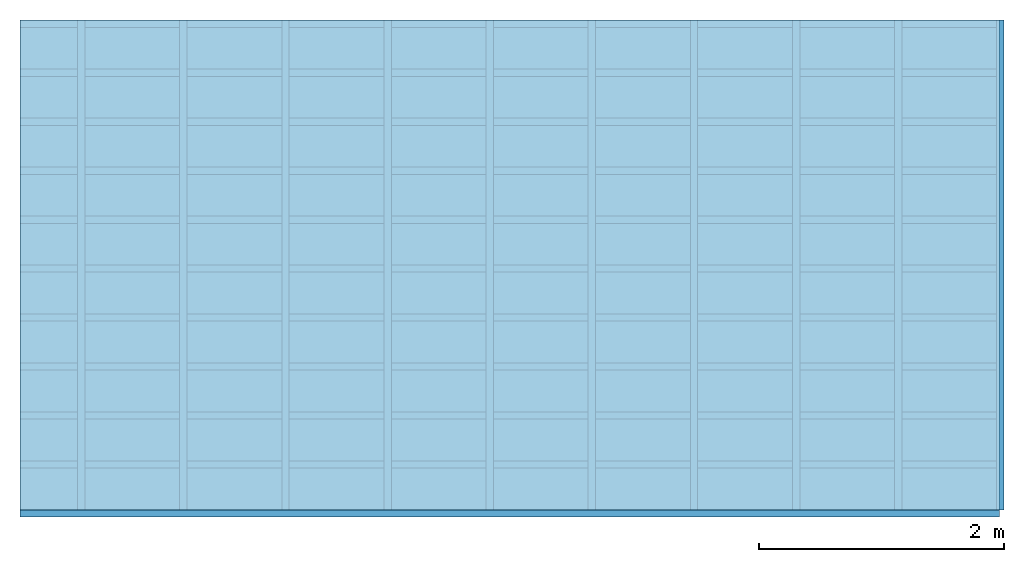
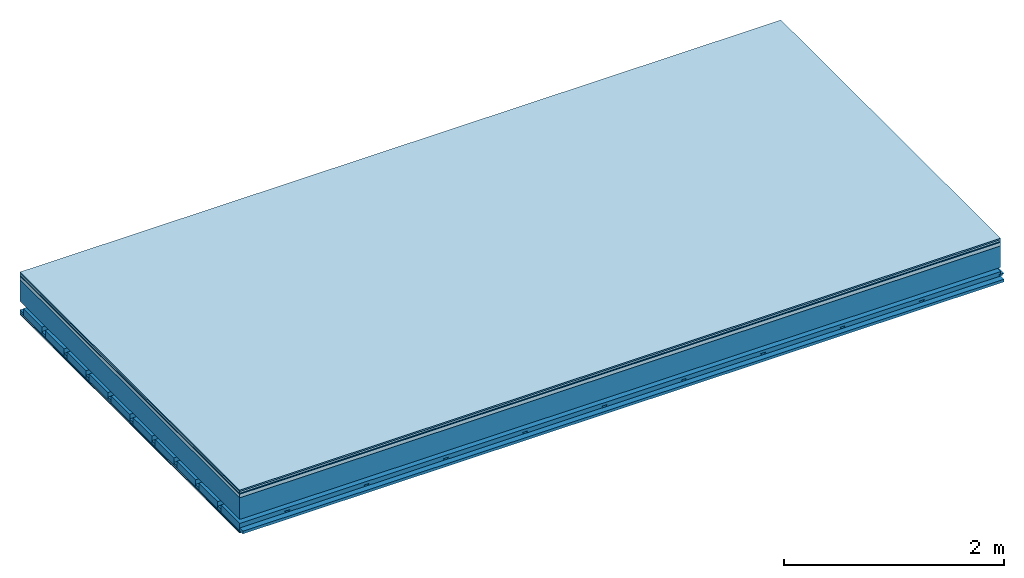
# One storey: 7 plates, 4 members, 1 element without a shape of its own.
"""IFC4 building model written with IfcOpenShell, lengths in metres."""

from ifc_helpers import new_model, si_unit, derived_unit, direction, frame, frame_2d, origin, origin_with_axes, place, context, project, spatial, polyline, rectangle, outline, extrude, material, layer, layer_set, type_object, element, aggregate, save


model = new_model("IFC4")

# Units and contexts
plan_context = context("Plan", 3, precision=1e-05, world=origin(), true_north=direction((0.0, 1.0)))
model_context = context("Model", 3, precision=1e-05, world=origin(), true_north=direction((0.0, 1.0)))
ifc_project = project(units=[si_unit("LENGTHUNIT", "METRE"), derived_unit("SOUNDPRESSUREUNIT", [(si_unit("PRESSUREUNIT", "PASCAL", prefix="MICRO"), 0)]), si_unit("ENERGYUNIT", "JOULE", prefix="MEGA"), si_unit("MASSUNIT", "GRAM", prefix="KILO"), derived_unit("THERMALTRANSMITTANCEUNIT", [(si_unit("POWERUNIT", "WATT"), 1), (si_unit("AREAUNIT", "SQUARE_METRE"), -1), (si_unit("THERMODYNAMICTEMPERATUREUNIT", "KELVIN"), -1)]), derived_unit("AREADENSITYUNIT", [(si_unit("MASSUNIT", "GRAM", prefix="KILO"), 1), (si_unit("AREAUNIT", "SQUARE_METRE"), -1)]), derived_unit("USERDEFINED", [(si_unit("ENERGYUNIT", "JOULE", prefix="MEGA"), 1), (si_unit("AREAUNIT", "SQUARE_METRE"), -1)])], contexts=[plan_context, model_context])

# Site, building, storey
site = spatial("IfcSite", under=ifc_project)
building_placement = place(None, origin())
building = spatial("IfcBuilding", under=site, at=building_placement)
storey_placement = place(building_placement, origin())
storey = spatial("IfcBuildingStorey", under=building, at=storey_placement)

# Slab, members, plates
ifc_material_1 = material(Category="11.013")
ifc_layer_1 = layer(ifc_material_1, 0.015, Name="Flooring")
ifc_material_2 = material(Category="03.007")
ifc_layer_2 = layer(ifc_material_2, 0.02, Name="On-material")
ifc_material_3 = material(Name="Wood fiber generic product", Category="10.009")
ifc_layer_3 = layer(ifc_material_3, 0.01, Name="Impact sound insulation")
ifc_material_4 = material(Name="Concrete panels", Category="02.007")
ifc_layer_4 = layer(ifc_material_4, 0.04, Name="on Supporting structure")
ifc_material_5 = material(Name="no composite action")
ifc_layer_5 = layer(ifc_material_5, 0.0, Name="Bond")
ifc_layer_6 = layer(None, 0.24, Name="Supporting structure")
ifc_layer_7 = layer(ifc_material_5, 0.0, Name="Bond")
ifc_layer_8 = layer(None, 0.095, Name="Coupling")
ifc_layer_9 = layer(None, 0.03, Name="Battens / profiles")
ifc_material_6 = material(Name="Plasterboard type A", Category="03.008")
ifc_layer_10 = layer(ifc_material_6, 0.0125, Name="Ceiling covering 1st layer")
ifc_layer_11 = layer(ifc_material_6, 0.0125, Name="Ceiling covering layer 2")
ifc_material_7 = material(Category="04.001")
ifc_layer_12 = layer(ifc_material_7, 0.003, Name="Surface / treatment")
ifc_layer_set = layer_set([ifc_layer_1, ifc_layer_2, ifc_layer_3, ifc_layer_4, ifc_layer_5, ifc_layer_6, ifc_layer_7, ifc_layer_8, ifc_layer_9, ifc_layer_10, ifc_layer_11, ifc_layer_12])
slab_type = type_object("IfcSlabType", Name="A2138", PredefinedType="NOTDEFINED", material=ifc_layer_set)
slab_placement = place(None, frame((0.0, 0.0, 0.0), z_axis=(0.0, 0.0, -1.0), x_axis=(1.0, 0.0, 0.0)))
slab = element("IfcSlab", 1, at=slab_placement, inside=storey, type_object=slab_type, material=ifc_layer_set, Name="Slab #1")
ifc_material_8 = material(Name="Solid timber panel")
member_1_placement = place(slab_placement, origin())
member_1 = element("IfcMember", 2, at=member_1_placement, material=ifc_material_8, Name="Supporting structure", context=plan_context, shape_type="SweptSolid", body=[
    extrude(rectangle(XDim=1.0, YDim=0.24, at=frame_2d((0.5, 0.12), x_axis=(1.0, 0.0))), frame((0.0, 4.0, 0.085), z_axis=(0.0, -1.0, 0.0), x_axis=(1.0, 0.0, 0.0)), (0.0, 0.0, 1.0), 4.0),
    extrude(rectangle(XDim=1.0, YDim=0.24, at=frame_2d((0.5, 0.12), x_axis=(1.0, 0.0))), frame((1.0, 4.0, 0.085), z_axis=(0.0, -1.0, 0.0), x_axis=(1.0, 0.0, 0.0)), (0.0, 0.0, 1.0), 4.0),
    extrude(rectangle(XDim=1.0, YDim=0.24, at=frame_2d((0.5, 0.12), x_axis=(1.0, 0.0))), frame((2.0, 4.0, 0.085), z_axis=(0.0, -1.0, 0.0), x_axis=(1.0, 0.0, 0.0)), (0.0, 0.0, 1.0), 4.0),
    extrude(rectangle(XDim=1.0, YDim=0.24, at=frame_2d((0.5, 0.12), x_axis=(1.0, 0.0))), frame((3.0, 4.0, 0.085), z_axis=(0.0, -1.0, 0.0), x_axis=(1.0, 0.0, 0.0)), (0.0, 0.0, 1.0), 4.0),
    extrude(rectangle(XDim=1.0, YDim=0.24, at=frame_2d((0.5, 0.12), x_axis=(1.0, 0.0))), frame((4.0, 4.0, 0.085), z_axis=(0.0, -1.0, 0.0), x_axis=(1.0, 0.0, 0.0)), (0.0, 0.0, 1.0), 4.0),
    extrude(rectangle(XDim=1.0, YDim=0.24, at=frame_2d((0.5, 0.12), x_axis=(1.0, 0.0))), frame((5.0, 4.0, 0.085), z_axis=(0.0, -1.0, 0.0), x_axis=(1.0, 0.0, 0.0)), (0.0, 0.0, 1.0), 4.0),
    extrude(rectangle(XDim=1.0, YDim=0.24, at=frame_2d((0.5, 0.12), x_axis=(1.0, 0.0))), frame((6.0, 4.0, 0.085), z_axis=(0.0, -1.0, 0.0), x_axis=(1.0, 0.0, 0.0)), (0.0, 0.0, 1.0), 4.0),
    extrude(rectangle(XDim=1.0, YDim=0.24, at=frame_2d((0.5, 0.12), x_axis=(1.0, 0.0))), frame((7.0, 4.0, 0.085), z_axis=(0.0, -1.0, 0.0), x_axis=(1.0, 0.0, 0.0)), (0.0, 0.0, 1.0), 4.0),
])
ifc_material_9 = material()
member_2_placement = place(slab_placement, origin())
member_2 = element("IfcMember", 3, at=member_2_placement, material=ifc_material_9, Name="Coupling", context=plan_context, shape_type="SweptSolid", body=[
    extrude(outline(polyline([(0.0, 0.0), (0.06, 0.0), (0.04, 0.02), (0.02, 0.02), (0.0, 0.0)])), frame((0.47, 4.0, 0.4), z_axis=(0.0, -1.0, 0.0), x_axis=(1.0, 0.0, 0.0)), (0.0, 0.0, 1.0), 4.0),
    extrude(outline(polyline([(0.0, 0.0), (0.06, 0.0), (0.04, 0.02), (0.02, 0.02), (0.0, 0.0)])), frame((1.304, 4.0, 0.4), z_axis=(0.0, -1.0, 0.0), x_axis=(1.0, 0.0, 0.0)), (0.0, 0.0, 1.0), 4.0),
    extrude(outline(polyline([(0.0, 0.0), (0.06, 0.0), (0.04, 0.02), (0.02, 0.02), (0.0, 0.0)])), frame((2.138, 4.0, 0.4), z_axis=(0.0, -1.0, 0.0), x_axis=(1.0, 0.0, 0.0)), (0.0, 0.0, 1.0), 4.0),
    extrude(outline(polyline([(0.0, 0.0), (0.06, 0.0), (0.04, 0.02), (0.02, 0.02), (0.0, 0.0)])), frame((2.972, 4.0, 0.4), z_axis=(0.0, -1.0, 0.0), x_axis=(1.0, 0.0, 0.0)), (0.0, 0.0, 1.0), 4.0),
    extrude(outline(polyline([(0.0, 0.0), (0.06, 0.0), (0.04, 0.02), (0.02, 0.02), (0.0, 0.0)])), frame((3.806, 4.0, 0.4), z_axis=(0.0, -1.0, 0.0), x_axis=(1.0, 0.0, 0.0)), (0.0, 0.0, 1.0), 4.0),
    extrude(outline(polyline([(0.0, 0.0), (0.06, 0.0), (0.04, 0.02), (0.02, 0.02), (0.0, 0.0)])), frame((4.64, 4.0, 0.4), z_axis=(0.0, -1.0, 0.0), x_axis=(1.0, 0.0, 0.0)), (0.0, 0.0, 1.0), 4.0),
    extrude(outline(polyline([(0.0, 0.0), (0.06, 0.0), (0.04, 0.02), (0.02, 0.02), (0.0, 0.0)])), frame((5.474, 4.0, 0.4), z_axis=(0.0, -1.0, 0.0), x_axis=(1.0, 0.0, 0.0)), (0.0, 0.0, 1.0), 4.0),
    extrude(outline(polyline([(0.0, 0.0), (0.06, 0.0), (0.04, 0.02), (0.02, 0.02), (0.0, 0.0)])), frame((6.308, 4.0, 0.4), z_axis=(0.0, -1.0, 0.0), x_axis=(1.0, 0.0, 0.0)), (0.0, 0.0, 1.0), 4.0),
    extrude(outline(polyline([(0.0, 0.0), (0.06, 0.0), (0.04, 0.02), (0.02, 0.02), (0.0, 0.0)])), frame((7.142, 4.0, 0.4), z_axis=(0.0, -1.0, 0.0), x_axis=(1.0, 0.0, 0.0)), (0.0, 0.0, 1.0), 4.0),
    extrude(outline(polyline([(0.0, 0.0), (0.06, 0.0), (0.04, 0.02), (0.02, 0.02), (0.0, 0.0)])), frame((7.976, 4.0, 0.4), z_axis=(0.0, -1.0, 0.0), x_axis=(1.0, 0.0, 0.0)), (0.0, 0.0, 1.0), 4.0),
])
member_3_placement = place(slab_placement, origin())
member_3 = element("IfcMember", 4, at=member_3_placement, material=ifc_material_9, Name="Battens / profiles", context=plan_context, shape_type="SweptSolid", body=[
    extrude(rectangle(XDim=0.06, YDim=0.03, at=frame_2d((0.03, 0.015), x_axis=(1.0, 0.0))), frame((0.0, 0.0, 0.42), z_axis=(1.0, 0.0, 0.0), x_axis=(0.0, 1.0, 0.0)), (0.0, 0.0, 1.0), 8.0),
    extrude(rectangle(XDim=0.06, YDim=0.03, at=frame_2d((0.03, 0.015), x_axis=(1.0, 0.0))), frame((0.0, 0.4, 0.42), z_axis=(1.0, 0.0, 0.0), x_axis=(0.0, 1.0, 0.0)), (0.0, 0.0, 1.0), 8.0),
    extrude(rectangle(XDim=0.06, YDim=0.03, at=frame_2d((0.03, 0.015), x_axis=(1.0, 0.0))), frame((0.0, 0.8, 0.42), z_axis=(1.0, 0.0, 0.0), x_axis=(0.0, 1.0, 0.0)), (0.0, 0.0, 1.0), 8.0),
    extrude(rectangle(XDim=0.06, YDim=0.03, at=frame_2d((0.03, 0.015), x_axis=(1.0, 0.0))), frame((0.0, 1.2, 0.42), z_axis=(1.0, 0.0, 0.0), x_axis=(0.0, 1.0, 0.0)), (0.0, 0.0, 1.0), 8.0),
    extrude(rectangle(XDim=0.06, YDim=0.03, at=frame_2d((0.03, 0.015), x_axis=(1.0, 0.0))), frame((0.0, 1.6, 0.42), z_axis=(1.0, 0.0, 0.0), x_axis=(0.0, 1.0, 0.0)), (0.0, 0.0, 1.0), 8.0),
    extrude(rectangle(XDim=0.06, YDim=0.03, at=frame_2d((0.03, 0.015), x_axis=(1.0, 0.0))), frame((0.0, 2.0, 0.42), z_axis=(1.0, 0.0, 0.0), x_axis=(0.0, 1.0, 0.0)), (0.0, 0.0, 1.0), 8.0),
    extrude(rectangle(XDim=0.06, YDim=0.03, at=frame_2d((0.03, 0.015), x_axis=(1.0, 0.0))), frame((0.0, 2.4, 0.42), z_axis=(1.0, 0.0, 0.0), x_axis=(0.0, 1.0, 0.0)), (0.0, 0.0, 1.0), 8.0),
    extrude(rectangle(XDim=0.06, YDim=0.03, at=frame_2d((0.03, 0.015), x_axis=(1.0, 0.0))), frame((0.0, 2.8, 0.42), z_axis=(1.0, 0.0, 0.0), x_axis=(0.0, 1.0, 0.0)), (0.0, 0.0, 1.0), 8.0),
    extrude(rectangle(XDim=0.06, YDim=0.03, at=frame_2d((0.03, 0.015), x_axis=(1.0, 0.0))), frame((0.0, 3.2, 0.42), z_axis=(1.0, 0.0, 0.0), x_axis=(0.0, 1.0, 0.0)), (0.0, 0.0, 1.0), 8.0),
    extrude(rectangle(XDim=0.06, YDim=0.03, at=frame_2d((0.03, 0.015), x_axis=(1.0, 0.0))), frame((0.0, 3.6, 0.42), z_axis=(1.0, 0.0, 0.0), x_axis=(0.0, 1.0, 0.0)), (0.0, 0.0, 1.0), 8.0),
    extrude(rectangle(XDim=0.06, YDim=0.03, at=frame_2d((0.03, 0.015), x_axis=(1.0, 0.0))), frame((0.0, 4.0, 0.42), z_axis=(1.0, 0.0, 0.0), x_axis=(0.0, 1.0, 0.0)), (0.0, 0.0, 1.0), 8.0),
])
ifc_material_10 = material()
member_4_placement = place(slab_placement, origin())
member_4 = element("IfcMember", 5, at=member_4_placement, material=ifc_material_10, Name="Cavity", context=plan_context, shape_type="SweptSolid", body=[
    extrude(rectangle(XDim=0.34, YDim=0.08, at=frame_2d((0.17, 0.04), x_axis=(1.0, 0.0))), frame((0.0, 0.06, 0.37), z_axis=(1.0, 0.0, 0.0), x_axis=(0.0, 1.0, 0.0)), (0.0, 0.0, 1.0), 8.0),
    extrude(rectangle(XDim=0.34, YDim=0.08, at=frame_2d((0.17, 0.04), x_axis=(1.0, 0.0))), frame((0.0, 0.46, 0.37), z_axis=(1.0, 0.0, 0.0), x_axis=(0.0, 1.0, 0.0)), (0.0, 0.0, 1.0), 8.0),
    extrude(rectangle(XDim=0.34, YDim=0.08, at=frame_2d((0.17, 0.04), x_axis=(1.0, 0.0))), frame((0.0, 0.86, 0.37), z_axis=(1.0, 0.0, 0.0), x_axis=(0.0, 1.0, 0.0)), (0.0, 0.0, 1.0), 8.0),
    extrude(rectangle(XDim=0.34, YDim=0.08, at=frame_2d((0.17, 0.04), x_axis=(1.0, 0.0))), frame((0.0, 1.26, 0.37), z_axis=(1.0, 0.0, 0.0), x_axis=(0.0, 1.0, 0.0)), (0.0, 0.0, 1.0), 8.0),
    extrude(rectangle(XDim=0.34, YDim=0.08, at=frame_2d((0.17, 0.04), x_axis=(1.0, 0.0))), frame((0.0, 1.66, 0.37), z_axis=(1.0, 0.0, 0.0), x_axis=(0.0, 1.0, 0.0)), (0.0, 0.0, 1.0), 8.0),
    extrude(rectangle(XDim=0.34, YDim=0.08, at=frame_2d((0.17, 0.04), x_axis=(1.0, 0.0))), frame((0.0, 2.06, 0.37), z_axis=(1.0, 0.0, 0.0), x_axis=(0.0, 1.0, 0.0)), (0.0, 0.0, 1.0), 8.0),
    extrude(rectangle(XDim=0.34, YDim=0.08, at=frame_2d((0.17, 0.04), x_axis=(1.0, 0.0))), frame((0.0, 2.46, 0.37), z_axis=(1.0, 0.0, 0.0), x_axis=(0.0, 1.0, 0.0)), (0.0, 0.0, 1.0), 8.0),
    extrude(rectangle(XDim=0.34, YDim=0.08, at=frame_2d((0.17, 0.04), x_axis=(1.0, 0.0))), frame((0.0, 2.86, 0.37), z_axis=(1.0, 0.0, 0.0), x_axis=(0.0, 1.0, 0.0)), (0.0, 0.0, 1.0), 8.0),
    extrude(rectangle(XDim=0.34, YDim=0.08, at=frame_2d((0.17, 0.04), x_axis=(1.0, 0.0))), frame((0.0, 3.26, 0.37), z_axis=(1.0, 0.0, 0.0), x_axis=(0.0, 1.0, 0.0)), (0.0, 0.0, 1.0), 8.0),
    extrude(rectangle(XDim=0.34, YDim=0.08, at=frame_2d((0.17, 0.04), x_axis=(1.0, 0.0))), frame((0.0, 3.66, 0.37), z_axis=(1.0, 0.0, 0.0), x_axis=(0.0, 1.0, 0.0)), (0.0, 0.0, 1.0), 8.0),
])
plate_1_placement = place(slab_placement, origin())
plate_1 = element("IfcPlate", 6, at=plate_1_placement, material=ifc_material_1, Name="Flooring", context=plan_context, shape_type="SweptSolid", body=[
    extrude(rectangle(XDim=8.0, YDim=4.0, at=frame_2d((4.0, 2.0), x_axis=(1.0, 0.0))), origin_with_axes(), (0.0, 0.0, 1.0), 0.015),
])
plate_2_placement = place(slab_placement, origin())
plate_2 = element("IfcPlate", 7, at=plate_2_placement, material=ifc_material_2, Name="On-material", context=plan_context, shape_type="SweptSolid", body=[
    extrude(rectangle(XDim=8.0, YDim=4.0, at=frame_2d((4.0, 2.0), x_axis=(1.0, 0.0))), frame((0.0, 0.0, 0.015), z_axis=(0.0, 0.0, 1.0), x_axis=(1.0, 0.0, 0.0)), (0.0, 0.0, 1.0), 0.02),
])
plate_3_placement = place(slab_placement, origin())
plate_3 = element("IfcPlate", 8, at=plate_3_placement, material=ifc_material_3, Name="Impact sound insulation", context=plan_context, shape_type="SweptSolid", body=[
    extrude(rectangle(XDim=8.0, YDim=4.0, at=frame_2d((4.0, 2.0), x_axis=(1.0, 0.0))), frame((0.0, 0.0, 0.035), z_axis=(0.0, 0.0, 1.0), x_axis=(1.0, 0.0, 0.0)), (0.0, 0.0, 1.0), 0.01),
])
plate_4_placement = place(slab_placement, origin())
plate_4 = element("IfcPlate", 9, at=plate_4_placement, material=ifc_material_4, Name="on Supporting structure", context=plan_context, shape_type="SweptSolid", body=[
    extrude(rectangle(XDim=8.0, YDim=4.0, at=frame_2d((4.0, 2.0), x_axis=(1.0, 0.0))), frame((0.0, 0.0, 0.045), z_axis=(0.0, 0.0, 1.0), x_axis=(1.0, 0.0, 0.0)), (0.0, 0.0, 1.0), 0.04),
])
plate_5_placement = place(slab_placement, origin())
plate_5 = element("IfcPlate", 10, at=plate_5_placement, material=ifc_material_6, Name="Ceiling covering 1st layer", context=plan_context, shape_type="SweptSolid", body=[
    extrude(rectangle(XDim=8.0, YDim=4.0, at=frame_2d((4.0, 2.0), x_axis=(1.0, 0.0))), frame((0.0, 0.0, 0.45), z_axis=(0.0, 0.0, 1.0), x_axis=(1.0, 0.0, 0.0)), (0.0, 0.0, 1.0), 0.0125),
])
plate_6_placement = place(slab_placement, origin())
plate_6 = element("IfcPlate", 11, at=plate_6_placement, material=ifc_material_6, Name="Ceiling covering layer 2", context=plan_context, shape_type="SweptSolid", body=[
    extrude(rectangle(XDim=8.0, YDim=4.0, at=frame_2d((4.0, 2.0), x_axis=(1.0, 0.0))), frame((0.0, 0.0, 0.4625), z_axis=(0.0, 0.0, 1.0), x_axis=(1.0, 0.0, 0.0)), (0.0, 0.0, 1.0), 0.0125),
])
plate_7_placement = place(slab_placement, origin())
plate_7 = element("IfcPlate", 12, at=plate_7_placement, material=ifc_material_7, Name="Surface / treatment", context=plan_context, shape_type="SweptSolid", body=[
    extrude(rectangle(XDim=8.0, YDim=4.0, at=frame_2d((4.0, 2.0), x_axis=(1.0, 0.0))), frame((0.0, 0.0, 0.475), z_axis=(0.0, 0.0, 1.0), x_axis=(1.0, 0.0, 0.0)), (0.0, 0.0, 1.0), 0.003),
])
aggregate(slab, [plate_1, plate_2, plate_3, plate_4, member_1, member_2, member_3, member_4, plate_5, plate_6, plate_7])

save(model, "model.ifc")
